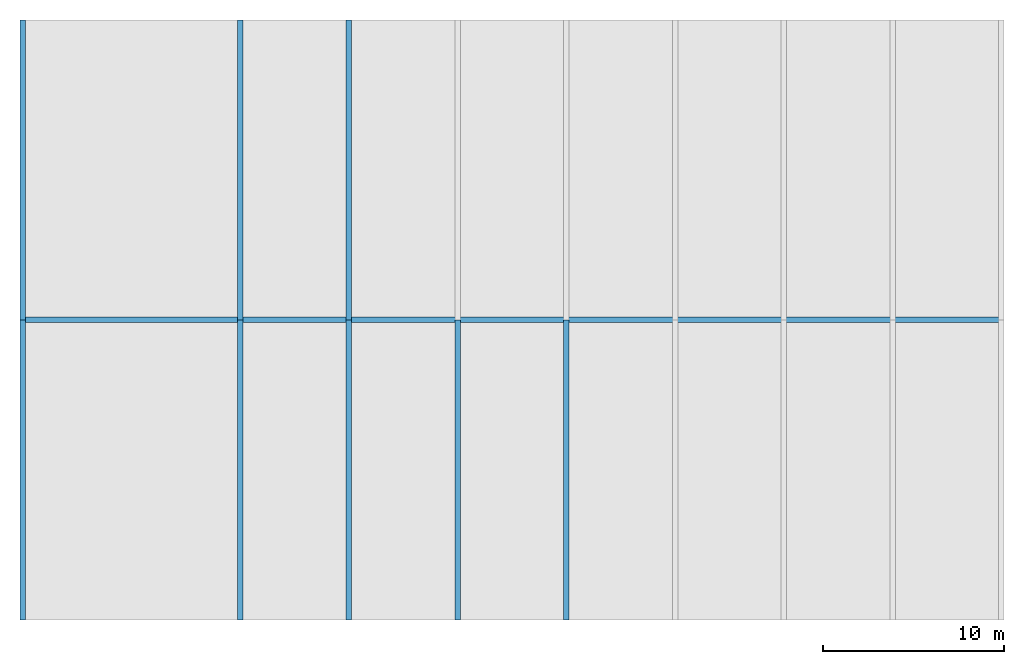
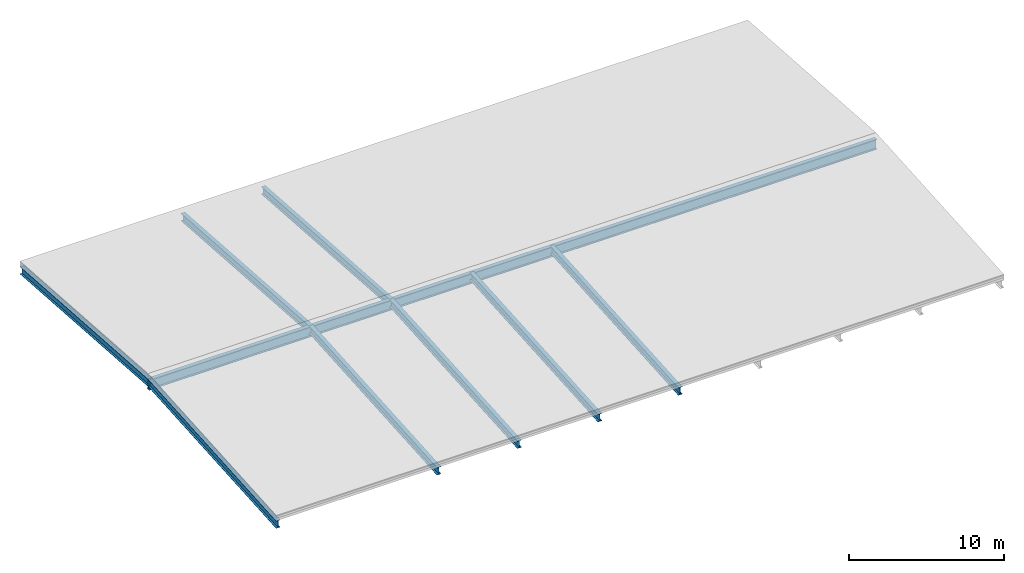
# One storey, part 1 of 3: 9 beams.
"""IFC2X3 building model written with IfcOpenShell, lengths in millimetres."""

from ifc_helpers import new_model, entity, si_unit, converted_unit, frame, origin, place, context, subcontext, project, spatial, faceted_brep, material, element, save


model = new_model("IFC2X3")

# Units and contexts
model_context = context("Model", 3, precision=1e-05, world=origin())
body_context = subcontext(model_context, "Body", "Model", "MODEL_VIEW")
ifc_project = project(units=[si_unit("LENGTHUNIT", "METRE", prefix="MILLI"), converted_unit("PLANEANGLEUNIT", "DEGREE", entity("IfcPlaneAngleMeasure", 0.0174532925199433), si_unit("PLANEANGLEUNIT", "RADIAN"), dimensions=[0, 0, 0, 0, 0, 0, 0]), si_unit("AREAUNIT", "SQUARE_METRE"), si_unit("VOLUMEUNIT", "CUBIC_METRE")], contexts=[model_context])

# Building, storey
building_placement = place(None, origin())
building = spatial("IfcBuilding", under=ifc_project, at=building_placement, CompositionType="ELEMENT")
storey_placement = place(building_placement, frame((0.0, 0.0, 7000.0), z_axis=(0.0, 0.0, 1.0), x_axis=(1.0, 0.0, 0.0)))
storey = spatial("IfcBuildingStorey", under=building, at=storey_placement, Name="Dach", CompositionType="ELEMENT", Elevation=7000.0)

# Beams
ifc_material_1 = material(Name="Stahl")
beam_1_placement = place(storey_placement, frame((-20.0, 16548.66666666668, 930.0), z_axis=(0.0, 0.0, 1.0), x_axis=(0.9999999996985275, 2.455494167264557e-05, 0.0)))
element("IfcBeam", 1, at=beam_1_placement, inside=storey, material=ifc_material_1, context=body_context, shape_type="Brep", body=[
    faceted_brep([(54300.00001637004, 0.0, 800.0), (54300.00001637004, 0.0, 767.0), (0.0, 0.0, 767.0), (0.0, 0.0, 800.0), (54300.00001637004, 0.0, 33.0), (54300.00001637004, 0.0, 0.0), (0.0, 0.0, 0.0), (0.0, 0.0, 33.0), (54300.00738285257, 299.9999999095599, 800.0), (54300.00738285258, 299.9999999095599, 767.0), (54300.00738285258, 158.7499999521424, 767.0), (54300.00738285258, 158.7499999521424, 33.0), (54300.00738285258, 299.9999999095599, 33.0), (54300.00738285257, 299.9999999095599, 0.0), (54300.00001637004, 0.0, 0.0), (54300.00001637004, 0.0, 33.0), (54300.00738285258, 141.2499999574175, 33.0), (54300.00738285258, 141.2499999574175, 767.0), (54300.00001637004, 0.0, 767.0), (54300.00001637004, 0.0, 800.0), (0.007399222424023577, 301.3333332424772, 33.0), (0.007399222424023577, 301.3333332424772, 0.0), (54300.00738285257, 299.9999999095599, 0.0), (54300.00738285258, 299.9999999095599, 33.0), (0.007399222424023577, 301.3333332424772, 800.0), (0.007399222424023577, 301.3333332424772, 767.0), (54300.00738285258, 299.9999999095599, 767.0), (54300.00738285257, 299.9999999095599, 800.0), (0.0, 0.0, 800.0), (0.0, 0.0, 767.0), (2.016520284087164e-11, 141.8777778205476, 767.0), (2.016520284087164e-11, 141.8777778205476, 33.0), (0.0, 0.0, 33.0), (0.0, 0.0, 0.0), (0.007399222424023577, 301.3333332424772, 0.0), (0.007399222424023577, 301.3333332424772, 33.0), (2.016520284087164e-11, 159.4555556036212, 33.0), (2.016520284087164e-11, 159.4555556036212, 767.0), (0.007399222424023577, 301.3333332424772, 767.0), (0.007399222424023577, 301.3333332424772, 800.0), (54300.00738285257, 299.9999999095599, 800.0), (54300.00001637004, 0.0, 800.0), (0.0, 0.0, 800.0), (0.007399222424023577, 301.3333332424772, 800.0), (54300.00001637004, 0.0, 767.0), (54300.00738285258, 141.2499999574175, 767.0), (2.016520284087164e-11, 141.8777778205476, 767.0), (0.0, 0.0, 767.0), (54300.00738285258, 141.2499999574175, 767.0), (54300.00738285258, 141.2499999574175, 33.0), (2.016520284087164e-11, 141.8777778205476, 33.0), (2.016520284087164e-11, 141.8777778205476, 767.0), (54300.00738285258, 141.2499999574175, 33.0), (54300.00001637004, 0.0, 33.0), (0.0, 0.0, 33.0), (2.016520284087164e-11, 141.8777778205476, 33.0), (54300.00001637004, 0.0, 0.0), (54300.00738285257, 299.9999999095599, 0.0), (0.007399222424023577, 301.3333332424772, 0.0), (0.0, 0.0, 0.0), (54300.00738285258, 299.9999999095599, 33.0), (54300.00738285258, 158.7499999521424, 33.0), (2.016520284087164e-11, 159.4555556036212, 33.0), (0.007399222424023577, 301.3333332424772, 33.0), (54300.00738285258, 158.7499999521424, 33.0), (54300.00738285258, 158.7499999521424, 767.0), (2.016520284087164e-11, 159.4555556036212, 767.0), (2.016520284087164e-11, 159.4555556036212, 33.0), (54300.00738285258, 158.7499999521424, 767.0), (54300.00738285258, 299.9999999095599, 767.0), (0.007399222424023577, 301.3333332424772, 767.0), (2.016520284087164e-11, 159.4555556036212, 767.0)], [[[0, 1, 2, 3]], [[4, 5, 6, 7]], [[8, 9, 10, 11, 12, 13, 14, 15, 16, 17, 18, 19]], [[20, 21, 22, 23]], [[24, 25, 26, 27]], [[28, 29, 30, 31, 32, 33, 34, 35, 36, 37, 38, 39]], [[40, 41, 42, 43]], [[44, 45, 46, 47]], [[48, 49, 50, 51]], [[52, 53, 54, 55]], [[56, 57, 58, 59]], [[60, 61, 62, 63]], [[64, 65, 66, 67]], [[68, 69, 70, 71]]], orient=[[False], [False], [False], [False], [False], [False], [False], [False], [False], [False], [False], [False], [False], [False]]),
])
ifc_material_2 = material(Name="Stahl")
beam_2_placement = place(storey_placement, frame((-20.0, 33250.0, -17.48170298587866), z_axis=(0.0, 0.0, 1.0), x_axis=(-5.296656030859425e-15, -1.0, 0.0)))
element("IfcBeam", 2, at=beam_2_placement, inside=storey, material=ifc_material_2, context=body_context, shape_type="Brep", body=[
    faceted_brep([(16550.00000000002, 0.0, 1757.288737665103), (16550.00000000002, -3.552713678800501e-15, 1727.288737665103), (0.0, 0.0, 570.0), (0.0, 0.0, 600.0), (16550.00000000002, 0.0, 1187.288737665102), (16550.00000000002, 0.0, 1157.288737665102), (0.0, -3.552713678800501e-15, 0.0), (0.0, 0.0, 30.00000000000091), (16550.00000000002, 300.0, 1757.288737665103), (16550.00000000002, 300.0, 1727.288737665103), (16550.00000000002, 157.75, 1727.288737665103), (16550.00000000002, 157.75, 1187.288737665102), (16550.00000000002, 300.0, 1187.288737665102), (16550.00000000002, 300.0, 1157.288737665102), (16550.00000000002, 0.0, 1157.288737665102), (16550.00000000002, 0.0, 1187.288737665102), (16550.00000000002, 142.25, 1187.288737665102), (16550.00000000002, 142.25, 1727.288737665103), (16550.00000000002, -3.552713678800501e-15, 1727.288737665103), (16550.00000000002, 0.0, 1757.288737665103), (0.0, 300.0, 30.0), (0.0, 300.0, 0.0), (16550.00000000002, 300.0, 1157.288737665102), (16550.00000000002, 300.0, 1187.288737665102), (0.0, 300.0, 600.0), (0.0, 300.0, 570.0), (16550.00000000002, 300.0, 1727.288737665103), (16550.00000000002, 300.0, 1757.288737665103), (0.0, 0.0, 600.0), (0.0, 0.0, 570.0), (0.0, 142.25, 570.0), (0.0, 142.25, 30.0), (0.0, 0.0, 30.00000000000091), (0.0, -3.552713678800501e-15, 0.0), (0.0, 300.0, 0.0), (0.0, 300.0, 30.0), (0.0, 157.75, 30.0), (0.0, 157.75, 570.0), (0.0, 300.0, 570.0), (0.0, 300.0, 600.0), (16550.00000000002, 300.0, 1757.288737665103), (16550.00000000002, 0.0, 1757.288737665103), (0.0, 0.0, 600.0), (0.0, 300.0, 600.0), (16550.00000000002, -3.552713678800501e-15, 1727.288737665103), (16550.00000000002, 142.25, 1727.288737665103), (0.0, 142.25, 570.0), (0.0, 0.0, 570.0), (16550.00000000002, 142.25, 1727.288737665103), (16550.00000000002, 142.25, 1187.288737665102), (0.0, 142.25, 30.0), (0.0, 142.25, 570.0), (16550.00000000002, 142.25, 1187.288737665102), (16550.00000000002, 0.0, 1187.288737665102), (0.0, 0.0, 30.00000000000091), (0.0, 142.25, 30.0), (16550.00000000002, 0.0, 1157.288737665102), (16550.00000000002, 300.0, 1157.288737665102), (0.0, 300.0, 0.0), (0.0, -3.552713678800501e-15, 0.0), (16550.00000000002, 300.0, 1187.288737665102), (16550.00000000002, 157.75, 1187.288737665102), (0.0, 157.75, 30.0), (0.0, 300.0, 30.0), (16550.00000000002, 157.75, 1187.288737665102), (16550.00000000002, 157.75, 1727.288737665103), (0.0, 157.75, 570.0), (0.0, 157.75, 30.0), (16550.00000000002, 157.75, 1727.288737665103), (16550.00000000002, 300.0, 1727.288737665103), (0.0, 300.0, 570.0), (0.0, 157.75, 570.0)], [[[0, 1, 2, 3]], [[4, 5, 6, 7]], [[8, 9, 10, 11, 12, 13, 14, 15, 16, 17, 18, 19]], [[20, 21, 22, 23]], [[24, 25, 26, 27]], [[28, 29, 30, 31, 32, 33, 34, 35, 36, 37, 38, 39]], [[40, 41, 42, 43]], [[44, 45, 46, 47]], [[48, 49, 50, 51]], [[52, 53, 54, 55]], [[56, 57, 58, 59]], [[60, 61, 62, 63]], [[64, 65, 66, 67]], [[68, 69, 70, 71]]], orient=[[False], [False], [False], [False], [False], [False], [False], [False], [False], [False], [False], [False], [False], [False]]),
])
ifc_material_3 = material(Name="Stahl")
beam_3_placement = place(storey_placement, frame((-20.00000000008766, 16699.99999999999, -17.48170298587684), z_axis=(0.0, 0.0, 1.0), x_axis=(5.296656030859434e-15, -1.0, 0.0)))
element("IfcBeam", 3, at=beam_3_placement, inside=storey, material=ifc_material_3, context=body_context, shape_type="Brep", body=[
    faceted_brep([(16549.99999999999, 0.0, 600.0), (16549.99999999999, 0.0, 570.0), (0.0, 0.0, 1727.288737665102), (0.0, 0.0, 1757.288737665102), (16549.99999999999, 0.0, 30.0), (16549.99999999999, 0.0, 0.0), (0.0, 0.0, 1157.2887376651), (0.0, 0.0, 1187.2887376651), (16549.99999999999, 300.0, 600.0), (16549.99999999999, 300.0, 570.0), (16549.99999999999, 157.75, 570.0), (16549.99999999999, 157.75, 30.0), (16549.99999999999, 300.0, 30.0), (16549.99999999999, 300.0, 0.0), (16549.99999999999, 0.0, 0.0), (16549.99999999999, 0.0, 30.0), (16549.99999999999, 142.25, 30.0), (16549.99999999999, 142.25, 570.0), (16549.99999999999, 0.0, 570.0), (16549.99999999999, 0.0, 600.0), (0.0, 300.0, 1187.2887376651), (0.0, 300.0, 1157.2887376651), (16549.99999999999, 300.0, 0.0), (16549.99999999999, 300.0, 30.0), (0.0, 300.0, 1757.288737665102), (0.0, 300.0, 1727.288737665102), (16549.99999999999, 300.0, 570.0), (16549.99999999999, 300.0, 600.0), (0.0, 0.0, 1757.288737665102), (0.0, 0.0, 1727.288737665102), (0.0, 142.25, 1727.288737665102), (0.0, 142.25, 1187.2887376651), (0.0, 0.0, 1187.2887376651), (0.0, 0.0, 1157.2887376651), (0.0, 300.0, 1157.2887376651), (0.0, 300.0, 1187.2887376651), (0.0, 157.75, 1187.2887376651), (0.0, 157.75, 1727.288737665102), (0.0, 300.0, 1727.288737665102), (0.0, 300.0, 1757.288737665102), (16549.99999999999, 300.0, 600.0), (16549.99999999999, 0.0, 600.0), (0.0, 0.0, 1757.288737665102), (0.0, 300.0, 1757.288737665102), (16549.99999999999, 0.0, 570.0), (16549.99999999999, 142.25, 570.0), (0.0, 142.25, 1727.288737665102), (0.0, 0.0, 1727.288737665102), (16549.99999999999, 142.25, 570.0), (16549.99999999999, 142.25, 30.0), (0.0, 142.25, 1187.2887376651), (0.0, 142.25, 1727.288737665102), (16549.99999999999, 142.25, 30.0), (16549.99999999999, 0.0, 30.0), (0.0, 0.0, 1187.2887376651), (0.0, 142.25, 1187.2887376651), (16549.99999999999, 0.0, 0.0), (16549.99999999999, 300.0, 0.0), (0.0, 300.0, 1157.2887376651), (0.0, 0.0, 1157.2887376651), (16549.99999999999, 300.0, 30.0), (16549.99999999999, 157.75, 30.0), (0.0, 157.75, 1187.2887376651), (0.0, 300.0, 1187.2887376651), (16549.99999999999, 157.75, 30.0), (16549.99999999999, 157.75, 570.0), (0.0, 157.75, 1727.288737665102), (0.0, 157.75, 1187.2887376651), (16549.99999999999, 157.75, 570.0), (16549.99999999999, 300.0, 570.0), (0.0, 300.0, 1727.288737665102), (0.0, 157.75, 1727.288737665102)], [[[0, 1, 2, 3]], [[4, 5, 6, 7]], [[8, 9, 10, 11, 12, 13, 14, 15, 16, 17, 18, 19]], [[20, 21, 22, 23]], [[24, 25, 26, 27]], [[28, 29, 30, 31, 32, 33, 34, 35, 36, 37, 38, 39]], [[40, 41, 42, 43]], [[44, 45, 46, 47]], [[48, 49, 50, 51]], [[52, 53, 54, 55]], [[56, 57, 58, 59]], [[60, 61, 62, 63]], [[64, 65, 66, 67]], [[68, 69, 70, 71]]], orient=[[False], [False], [False], [False], [False], [False], [False], [False], [False], [False], [False], [False], [False], [False]]),
])
ifc_material_4 = material(Name="Stahl")
beam_4_placement = place(storey_placement, frame((11980.0, 33250.0, -17.48170298587866), z_axis=(0.0, 0.0, 1.0), x_axis=(-5.27561881390943e-15, -1.0, 0.0)))
element("IfcBeam", 4, at=beam_4_placement, inside=storey, material=ifc_material_4, context=body_context, shape_type="Brep", body=[
    faceted_brep([(16550.00000000002, 0.0, 1757.288737665103), (16550.00000000002, 0.0, 1727.288737665102), (0.0, 0.0, 570.0), (0.0, 0.0, 600.0), (16550.00000000002, 0.0, 1187.288737665102), (16550.00000000002, 0.0, 1157.288737665102), (0.0, 1.818989403545857e-12, 0.0), (0.0, 0.0, 30.0), (16550.00000000001, 300.0, 1757.288737665103), (16550.00000000001, 300.0, 1727.288737665102), (16550.00000000001, 157.75, 1727.288737665102), (16550.00000000001, 157.75, 1187.288737665102), (16550.00000000001, 300.0, 1187.288737665102), (16550.00000000001, 300.0, 1157.288737665102), (16550.00000000002, 0.0, 1157.288737665102), (16550.00000000002, 0.0, 1187.288737665102), (16550.00000000001, 142.25, 1187.288737665102), (16550.00000000001, 142.25, 1727.288737665102), (16550.00000000002, 0.0, 1727.288737665102), (16550.00000000002, 0.0, 1757.288737665103), (0.0, 300.0, 30.0), (0.0, 300.0, 0.0), (16550.00000000001, 300.0, 1157.288737665102), (16550.00000000001, 300.0, 1187.288737665102), (0.0, 300.0, 600.0), (0.0, 300.0, 570.0), (16550.00000000001, 300.0, 1727.288737665102), (16550.00000000001, 300.0, 1757.288737665103), (0.0, 0.0, 600.0), (0.0, 0.0, 570.0), (0.0, 142.25, 570.0), (0.0, 142.2500000000018, 30.0), (0.0, 0.0, 30.0), (0.0, 1.818989403545857e-12, 0.0), (0.0, 300.0, 0.0), (0.0, 300.0, 30.0), (0.0, 157.75, 30.0), (0.0, 157.75, 570.0), (0.0, 300.0, 570.0), (0.0, 300.0, 600.0), (16550.00000000001, 300.0, 1757.288737665103), (16550.00000000002, 0.0, 1757.288737665103), (0.0, 0.0, 600.0), (0.0, 300.0, 600.0), (16550.00000000002, 0.0, 1727.288737665102), (16550.00000000001, 142.25, 1727.288737665102), (0.0, 142.25, 570.0), (0.0, 0.0, 570.0), (16550.00000000001, 142.25, 1727.288737665102), (16550.00000000001, 142.25, 1187.288737665102), (0.0, 142.2500000000018, 30.0), (0.0, 142.25, 570.0), (16550.00000000001, 142.25, 1187.288737665102), (16550.00000000002, 0.0, 1187.288737665102), (0.0, 0.0, 30.0), (0.0, 142.2500000000018, 30.0), (16550.00000000002, 0.0, 1157.288737665102), (16550.00000000001, 300.0, 1157.288737665102), (0.0, 300.0, 0.0), (0.0, 1.818989403545857e-12, 0.0), (16550.00000000001, 300.0, 1187.288737665102), (16550.00000000001, 157.75, 1187.288737665102), (0.0, 157.75, 30.0), (0.0, 300.0, 30.0), (16550.00000000001, 157.75, 1187.288737665102), (16550.00000000001, 157.75, 1727.288737665102), (0.0, 157.75, 570.0), (0.0, 157.75, 30.0), (16550.00000000001, 157.75, 1727.288737665102), (16550.00000000001, 300.0, 1727.288737665102), (0.0, 300.0, 570.0), (0.0, 157.75, 570.0)], [[[0, 1, 2, 3]], [[4, 5, 6, 7]], [[8, 9, 10, 11, 12, 13, 14, 15, 16, 17, 18, 19]], [[20, 21, 22, 23]], [[24, 25, 26, 27]], [[28, 29, 30, 31, 32, 33, 34, 35, 36, 37, 38, 39]], [[40, 41, 42, 43]], [[44, 45, 46, 47]], [[48, 49, 50, 51]], [[52, 53, 54, 55]], [[56, 57, 58, 59]], [[60, 61, 62, 63]], [[64, 65, 66, 67]], [[68, 69, 70, 71]]], orient=[[False], [False], [False], [False], [False], [False], [False], [False], [False], [False], [False], [False], [False], [False]]),
])
ifc_material_5 = material(Name="Stahl")
beam_5_placement = place(storey_placement, frame((11979.99999999991, 16699.99999999999, -17.48170298587684), z_axis=(0.0, 0.0, 1.0), x_axis=(5.275618813909437e-15, -1.0, 0.0)))
element("IfcBeam", 5, at=beam_5_placement, inside=storey, material=ifc_material_5, context=body_context, shape_type="Brep", body=[
    faceted_brep([(16549.99999999999, 0.0, 600.0000000000009), (16549.99999999999, 0.0, 570.0000000000009), (0.0, 0.0, 1727.288737665102), (0.0, 0.0, 1757.288737665102), (16549.99999999999, 0.0, 30.0), (16549.99999999999, 0.0, 0.0), (0.0, 0.0, 1157.2887376651), (0.0, 0.0, 1187.2887376651), (16549.99999999999, 300.0, 600.0000000000009), (16549.99999999999, 300.0, 570.0000000000009), (16549.99999999999, 157.75, 570.0000000000009), (16549.99999999999, 157.75, 30.0), (16549.99999999999, 300.0, 30.0), (16549.99999999999, 300.0, 0.0), (16549.99999999999, 0.0, 0.0), (16549.99999999999, 0.0, 30.0), (16549.99999999999, 142.25, 30.0), (16549.99999999999, 142.25, 570.0000000000009), (16549.99999999999, 0.0, 570.0000000000009), (16549.99999999999, 0.0, 600.0000000000009), (3.637978807091713e-12, 300.0, 1187.2887376651), (3.637978807091713e-12, 300.0, 1157.2887376651), (16549.99999999999, 300.0, 0.0), (16549.99999999999, 300.0, 30.0), (3.637978807091713e-12, 300.0, 1757.288737665102), (3.637978807091713e-12, 300.0, 1727.288737665102), (16549.99999999999, 300.0, 570.0000000000009), (16549.99999999999, 300.0, 600.0000000000009), (0.0, 0.0, 1757.288737665102), (0.0, 0.0, 1727.288737665102), (3.637978807091713e-12, 142.25, 1727.288737665102), (3.637978807091713e-12, 142.25, 1187.2887376651), (0.0, 0.0, 1187.2887376651), (0.0, 0.0, 1157.2887376651), (3.637978807091713e-12, 300.0, 1157.2887376651), (3.637978807091713e-12, 300.0, 1187.2887376651), (3.637978807091713e-12, 157.75, 1187.2887376651), (3.637978807091713e-12, 157.75, 1727.288737665102), (3.637978807091713e-12, 300.0, 1727.288737665102), (3.637978807091713e-12, 300.0, 1757.288737665102), (16549.99999999999, 300.0, 600.0000000000009), (16549.99999999999, 0.0, 600.0000000000009), (0.0, 0.0, 1757.288737665102), (3.637978807091713e-12, 300.0, 1757.288737665102), (16549.99999999999, 0.0, 570.0000000000009), (16549.99999999999, 142.25, 570.0000000000009), (3.637978807091713e-12, 142.25, 1727.288737665102), (0.0, 0.0, 1727.288737665102), (16549.99999999999, 142.25, 570.0000000000009), (16549.99999999999, 142.25, 30.0), (3.637978807091713e-12, 142.25, 1187.2887376651), (3.637978807091713e-12, 142.25, 1727.288737665102), (16549.99999999999, 142.25, 30.0), (16549.99999999999, 0.0, 30.0), (0.0, 0.0, 1187.2887376651), (3.637978807091713e-12, 142.25, 1187.2887376651), (16549.99999999999, 0.0, 0.0), (16549.99999999999, 300.0, 0.0), (3.637978807091713e-12, 300.0, 1157.2887376651), (0.0, 0.0, 1157.2887376651), (16549.99999999999, 300.0, 30.0), (16549.99999999999, 157.75, 30.0), (3.637978807091713e-12, 157.75, 1187.2887376651), (3.637978807091713e-12, 300.0, 1187.2887376651), (16549.99999999999, 157.75, 30.0), (16549.99999999999, 157.75, 570.0000000000009), (3.637978807091713e-12, 157.75, 1727.288737665102), (3.637978807091713e-12, 157.75, 1187.2887376651), (16549.99999999999, 157.75, 570.0000000000009), (16549.99999999999, 300.0, 570.0000000000009), (3.637978807091713e-12, 300.0, 1727.288737665102), (3.637978807091713e-12, 157.75, 1727.288737665102)], [[[0, 1, 2, 3]], [[4, 5, 6, 7]], [[8, 9, 10, 11, 12, 13, 14, 15, 16, 17, 18, 19]], [[20, 21, 22, 23]], [[24, 25, 26, 27]], [[28, 29, 30, 31, 32, 33, 34, 35, 36, 37, 38, 39]], [[40, 41, 42, 43]], [[44, 45, 46, 47]], [[48, 49, 50, 51]], [[52, 53, 54, 55]], [[56, 57, 58, 59]], [[60, 61, 62, 63]], [[64, 65, 66, 67]], [[68, 69, 70, 71]]], orient=[[False], [False], [False], [False], [False], [False], [False], [False], [False], [False], [False], [False], [False], [False]]),
])
ifc_material_6 = material(Name="Stahl")
beam_6_placement = place(storey_placement, frame((29979.99999999991, 16699.99999999999, -17.48170298587684), z_axis=(0.0, 0.0, 1.0), x_axis=(5.275618813909437e-15, -1.0, 0.0)))
element("IfcBeam", 6, at=beam_6_placement, inside=storey, material=ifc_material_6, context=body_context, shape_type="Brep", body=[
    faceted_brep([(16549.99999999999, 0.0, 600.0000000000009), (16549.99999999999, 0.0, 570.0000000000009), (0.0, 0.0, 1727.288737665102), (0.0, 0.0, 1757.288737665102), (16549.99999999999, 0.0, 30.0), (16549.99999999999, 0.0, 0.0), (0.0, 0.0, 1157.2887376651), (0.0, 0.0, 1187.2887376651), (16549.99999999999, 300.0, 600.0000000000009), (16549.99999999999, 300.0, 570.0000000000009), (16549.99999999999, 157.75, 570.0000000000009), (16549.99999999999, 157.75, 30.0), (16549.99999999999, 300.0, 30.0), (16549.99999999999, 300.0, 0.0), (16549.99999999999, 0.0, 0.0), (16549.99999999999, 0.0, 30.0), (16549.99999999999, 142.25, 30.0), (16549.99999999999, 142.25, 570.0000000000009), (16549.99999999999, 0.0, 570.0000000000009), (16549.99999999999, 0.0, 600.0000000000009), (3.637978807091713e-12, 300.0, 1187.2887376651), (3.637978807091713e-12, 300.0, 1157.2887376651), (16549.99999999999, 300.0, 0.0), (16549.99999999999, 300.0, 30.0), (3.637978807091713e-12, 300.0, 1757.288737665102), (3.637978807091713e-12, 300.0, 1727.288737665102), (16549.99999999999, 300.0, 570.0000000000009), (16549.99999999999, 300.0, 600.0000000000009), (0.0, 0.0, 1757.288737665102), (0.0, 0.0, 1727.288737665102), (3.637978807091713e-12, 142.25, 1727.288737665102), (3.637978807091713e-12, 142.25, 1187.2887376651), (0.0, 0.0, 1187.2887376651), (0.0, 0.0, 1157.2887376651), (3.637978807091713e-12, 300.0, 1157.2887376651), (3.637978807091713e-12, 300.0, 1187.2887376651), (3.637978807091713e-12, 157.75, 1187.2887376651), (3.637978807091713e-12, 157.75, 1727.288737665102), (3.637978807091713e-12, 300.0, 1727.288737665102), (3.637978807091713e-12, 300.0, 1757.288737665102), (16549.99999999999, 300.0, 600.0000000000009), (16549.99999999999, 0.0, 600.0000000000009), (0.0, 0.0, 1757.288737665102), (3.637978807091713e-12, 300.0, 1757.288737665102), (16549.99999999999, 0.0, 570.0000000000009), (16549.99999999999, 142.25, 570.0000000000009), (3.637978807091713e-12, 142.25, 1727.288737665102), (0.0, 0.0, 1727.288737665102), (16549.99999999999, 142.25, 570.0000000000009), (16549.99999999999, 142.25, 30.0), (3.637978807091713e-12, 142.25, 1187.2887376651), (3.637978807091713e-12, 142.25, 1727.288737665102), (16549.99999999999, 142.25, 30.0), (16549.99999999999, 0.0, 30.0), (0.0, 0.0, 1187.2887376651), (3.637978807091713e-12, 142.25, 1187.2887376651), (16549.99999999999, 0.0, 0.0), (16549.99999999999, 300.0, 0.0), (3.637978807091713e-12, 300.0, 1157.2887376651), (0.0, 0.0, 1157.2887376651), (16549.99999999999, 300.0, 30.0), (16549.99999999999, 157.75, 30.0), (3.637978807091713e-12, 157.75, 1187.2887376651), (3.637978807091713e-12, 300.0, 1187.2887376651), (16549.99999999999, 157.75, 30.0), (16549.99999999999, 157.75, 570.0000000000009), (3.637978807091713e-12, 157.75, 1727.288737665102), (3.637978807091713e-12, 157.75, 1187.2887376651), (16549.99999999999, 157.75, 570.0000000000009), (16549.99999999999, 300.0, 570.0000000000009), (3.637978807091713e-12, 300.0, 1727.288737665102), (3.637978807091713e-12, 157.75, 1727.288737665102)], [[[0, 1, 2, 3]], [[4, 5, 6, 7]], [[8, 9, 10, 11, 12, 13, 14, 15, 16, 17, 18, 19]], [[20, 21, 22, 23]], [[24, 25, 26, 27]], [[28, 29, 30, 31, 32, 33, 34, 35, 36, 37, 38, 39]], [[40, 41, 42, 43]], [[44, 45, 46, 47]], [[48, 49, 50, 51]], [[52, 53, 54, 55]], [[56, 57, 58, 59]], [[60, 61, 62, 63]], [[64, 65, 66, 67]], [[68, 69, 70, 71]]], orient=[[False], [False], [False], [False], [False], [False], [False], [False], [False], [False], [False], [False], [False], [False]]),
])
ifc_material_7 = material(Name="Stahl")
beam_7_placement = place(storey_placement, frame((23979.99999999991, 16699.99999999999, -17.48170298587684), z_axis=(0.0, 0.0, 1.0), x_axis=(5.275618813909437e-15, -1.0, 0.0)))
element("IfcBeam", 7, at=beam_7_placement, inside=storey, material=ifc_material_7, context=body_context, shape_type="Brep", body=[
    faceted_brep([(16549.99999999999, 0.0, 600.0000000000009), (16549.99999999999, 0.0, 570.0000000000009), (0.0, 0.0, 1727.288737665102), (0.0, 0.0, 1757.288737665102), (16549.99999999999, 0.0, 30.0), (16549.99999999999, 0.0, 0.0), (0.0, 0.0, 1157.2887376651), (0.0, 0.0, 1187.2887376651), (16549.99999999999, 300.0, 600.0000000000009), (16549.99999999999, 300.0, 570.0000000000009), (16549.99999999999, 157.75, 570.0000000000009), (16549.99999999999, 157.75, 30.0), (16549.99999999999, 300.0, 30.0), (16549.99999999999, 300.0, 0.0), (16549.99999999999, 0.0, 0.0), (16549.99999999999, 0.0, 30.0), (16549.99999999999, 142.25, 30.0), (16549.99999999999, 142.25, 570.0000000000009), (16549.99999999999, 0.0, 570.0000000000009), (16549.99999999999, 0.0, 600.0000000000009), (0.0, 300.0, 1187.2887376651), (0.0, 300.0, 1157.2887376651), (16549.99999999999, 300.0, 0.0), (16549.99999999999, 300.0, 30.0), (0.0, 300.0, 1757.288737665102), (0.0, 300.0, 1727.288737665102), (16549.99999999999, 300.0, 570.0000000000009), (16549.99999999999, 300.0, 600.0000000000009), (0.0, 0.0, 1757.288737665102), (0.0, 0.0, 1727.288737665102), (0.0, 142.25, 1727.288737665102), (0.0, 142.25, 1187.2887376651), (0.0, 0.0, 1187.2887376651), (0.0, 0.0, 1157.2887376651), (0.0, 300.0, 1157.2887376651), (0.0, 300.0, 1187.2887376651), (0.0, 157.75, 1187.2887376651), (0.0, 157.75, 1727.288737665102), (0.0, 300.0, 1727.288737665102), (0.0, 300.0, 1757.288737665102), (16549.99999999999, 300.0, 600.0000000000009), (16549.99999999999, 0.0, 600.0000000000009), (0.0, 0.0, 1757.288737665102), (0.0, 300.0, 1757.288737665102), (16549.99999999999, 0.0, 570.0000000000009), (16549.99999999999, 142.25, 570.0000000000009), (0.0, 142.25, 1727.288737665102), (0.0, 0.0, 1727.288737665102), (16549.99999999999, 142.25, 570.0000000000009), (16549.99999999999, 142.25, 30.0), (0.0, 142.25, 1187.2887376651), (0.0, 142.25, 1727.288737665102), (16549.99999999999, 142.25, 30.0), (16549.99999999999, 0.0, 30.0), (0.0, 0.0, 1187.2887376651), (0.0, 142.25, 1187.2887376651), (16549.99999999999, 0.0, 0.0), (16549.99999999999, 300.0, 0.0), (0.0, 300.0, 1157.2887376651), (0.0, 0.0, 1157.2887376651), (16549.99999999999, 300.0, 30.0), (16549.99999999999, 157.75, 30.0), (0.0, 157.75, 1187.2887376651), (0.0, 300.0, 1187.2887376651), (16549.99999999999, 157.75, 30.0), (16549.99999999999, 157.75, 570.0000000000009), (0.0, 157.75, 1727.288737665102), (0.0, 157.75, 1187.2887376651), (16549.99999999999, 157.75, 570.0000000000009), (16549.99999999999, 300.0, 570.0000000000009), (0.0, 300.0, 1727.288737665102), (0.0, 157.75, 1727.288737665102)], [[[0, 1, 2, 3]], [[4, 5, 6, 7]], [[8, 9, 10, 11, 12, 13, 14, 15, 16, 17, 18, 19]], [[20, 21, 22, 23]], [[24, 25, 26, 27]], [[28, 29, 30, 31, 32, 33, 34, 35, 36, 37, 38, 39]], [[40, 41, 42, 43]], [[44, 45, 46, 47]], [[48, 49, 50, 51]], [[52, 53, 54, 55]], [[56, 57, 58, 59]], [[60, 61, 62, 63]], [[64, 65, 66, 67]], [[68, 69, 70, 71]]], orient=[[False], [False], [False], [False], [False], [False], [False], [False], [False], [False], [False], [False], [False], [False]]),
])
ifc_material_8 = material(Name="Stahl")
beam_8_placement = place(storey_placement, frame((17979.99999999991, 16699.99999999999, -17.48170298587684), z_axis=(0.0, 0.0, 1.0), x_axis=(5.275618813909437e-15, -1.0, 0.0)))
element("IfcBeam", 8, at=beam_8_placement, inside=storey, material=ifc_material_8, context=body_context, shape_type="Brep", body=[
    faceted_brep([(16549.99999999999, 0.0, 600.0000000000009), (16549.99999999999, 0.0, 570.0000000000009), (0.0, 0.0, 1727.288737665102), (0.0, 0.0, 1757.288737665102), (16549.99999999999, 0.0, 30.0), (16549.99999999999, 0.0, 0.0), (0.0, 0.0, 1157.2887376651), (0.0, 0.0, 1187.2887376651), (16549.99999999999, 300.0, 600.0000000000009), (16549.99999999999, 300.0, 570.0000000000009), (16549.99999999999, 157.75, 570.0000000000009), (16549.99999999999, 157.75, 30.0), (16549.99999999999, 300.0, 30.0), (16549.99999999999, 300.0, 0.0), (16549.99999999999, 0.0, 0.0), (16549.99999999999, 0.0, 30.0), (16549.99999999999, 142.25, 30.0), (16549.99999999999, 142.25, 570.0000000000009), (16549.99999999999, 0.0, 570.0000000000009), (16549.99999999999, 0.0, 600.0000000000009), (3.637978807091713e-12, 300.0, 1187.2887376651), (3.637978807091713e-12, 300.0, 1157.2887376651), (16549.99999999999, 300.0, 0.0), (16549.99999999999, 300.0, 30.0), (3.637978807091713e-12, 300.0, 1757.288737665102), (3.637978807091713e-12, 300.0, 1727.288737665102), (16549.99999999999, 300.0, 570.0000000000009), (16549.99999999999, 300.0, 600.0000000000009), (0.0, 0.0, 1757.288737665102), (0.0, 0.0, 1727.288737665102), (0.0, 142.25, 1727.288737665102), (0.0, 142.25, 1187.2887376651), (0.0, 0.0, 1187.2887376651), (0.0, 0.0, 1157.2887376651), (3.637978807091713e-12, 300.0, 1157.2887376651), (3.637978807091713e-12, 300.0, 1187.2887376651), (0.0, 157.75, 1187.2887376651), (0.0, 157.75, 1727.288737665102), (3.637978807091713e-12, 300.0, 1727.288737665102), (3.637978807091713e-12, 300.0, 1757.288737665102), (16549.99999999999, 300.0, 600.0000000000009), (16549.99999999999, 0.0, 600.0000000000009), (0.0, 0.0, 1757.288737665102), (3.637978807091713e-12, 300.0, 1757.288737665102), (16549.99999999999, 0.0, 570.0000000000009), (16549.99999999999, 142.25, 570.0000000000009), (0.0, 142.25, 1727.288737665102), (0.0, 0.0, 1727.288737665102), (16549.99999999999, 142.25, 570.0000000000009), (16549.99999999999, 142.25, 30.0), (0.0, 142.25, 1187.2887376651), (0.0, 142.25, 1727.288737665102), (16549.99999999999, 142.25, 30.0), (16549.99999999999, 0.0, 30.0), (0.0, 0.0, 1187.2887376651), (0.0, 142.25, 1187.2887376651), (16549.99999999999, 0.0, 0.0), (16549.99999999999, 300.0, 0.0), (3.637978807091713e-12, 300.0, 1157.2887376651), (0.0, 0.0, 1157.2887376651), (16549.99999999999, 300.0, 30.0), (16549.99999999999, 157.75, 30.0), (0.0, 157.75, 1187.2887376651), (3.637978807091713e-12, 300.0, 1187.2887376651), (16549.99999999999, 157.75, 30.0), (16549.99999999999, 157.75, 570.0000000000009), (0.0, 157.75, 1727.288737665102), (0.0, 157.75, 1187.2887376651), (16549.99999999999, 157.75, 570.0000000000009), (16549.99999999999, 300.0, 570.0000000000009), (3.637978807091713e-12, 300.0, 1727.288737665102), (0.0, 157.75, 1727.288737665102)], [[[0, 1, 2, 3]], [[4, 5, 6, 7]], [[8, 9, 10, 11, 12, 13, 14, 15, 16, 17, 18, 19]], [[20, 21, 22, 23]], [[24, 25, 26, 27]], [[28, 29, 30, 31, 32, 33, 34, 35, 36, 37, 38, 39]], [[40, 41, 42, 43]], [[44, 45, 46, 47]], [[48, 49, 50, 51]], [[52, 53, 54, 55]], [[56, 57, 58, 59]], [[60, 61, 62, 63]], [[64, 65, 66, 67]], [[68, 69, 70, 71]]], orient=[[False], [False], [False], [False], [False], [False], [False], [False], [False], [False], [False], [False], [False], [False]]),
])
ifc_material_9 = material(Name="Stahl")
beam_9_placement = place(storey_placement, frame((17980.0, 33250.0, -17.48170298587866), z_axis=(0.0, 0.0, 1.0), x_axis=(-5.27561881390943e-15, -1.0, 0.0)))
element("IfcBeam", 9, at=beam_9_placement, inside=storey, material=ifc_material_9, context=body_context, shape_type="Brep", body=[
    faceted_brep([(16550.00000000001, 0.0, 1757.288737665103), (16550.00000000001, 0.0, 1727.288737665102), (0.0, 0.0, 570.0), (0.0, 0.0, 600.0), (16550.00000000001, 0.0, 1187.288737665102), (16550.00000000001, 0.0, 1157.288737665102), (0.0, 0.0, 0.0), (0.0, 0.0, 30.0), (16550.00000000001, 300.0, 1757.288737665103), (16550.00000000001, 300.0, 1727.288737665102), (16550.00000000001, 157.75, 1727.288737665102), (16550.00000000001, 157.75, 1187.288737665102), (16550.00000000001, 300.0, 1187.288737665102), (16550.00000000001, 300.0, 1157.288737665102), (16550.00000000001, 0.0, 1157.288737665102), (16550.00000000001, 0.0, 1187.288737665102), (16550.00000000001, 142.25, 1187.288737665102), (16550.00000000001, 142.25, 1727.288737665102), (16550.00000000001, 0.0, 1727.288737665102), (16550.00000000001, 0.0, 1757.288737665103), (0.0, 300.0, 30.0), (0.0, 300.0, 0.0), (16550.00000000001, 300.0, 1157.288737665102), (16550.00000000001, 300.0, 1187.288737665102), (0.0, 300.0, 600.0), (0.0, 300.0, 570.0), (16550.00000000001, 300.0, 1727.288737665102), (16550.00000000001, 300.0, 1757.288737665103), (0.0, 0.0, 600.0), (0.0, 0.0, 570.0), (0.0, 142.2500000000036, 570.0), (0.0, 142.2500000000036, 30.0), (0.0, 0.0, 30.0), (0.0, 0.0, 0.0), (0.0, 300.0, 0.0), (0.0, 300.0, 30.0), (0.0, 157.75, 30.0), (0.0, 157.75, 570.0), (0.0, 300.0, 570.0), (0.0, 300.0, 600.0), (16550.00000000001, 300.0, 1757.288737665103), (16550.00000000001, 0.0, 1757.288737665103), (0.0, 0.0, 600.0), (0.0, 300.0, 600.0), (16550.00000000001, 0.0, 1727.288737665102), (16550.00000000001, 142.25, 1727.288737665102), (0.0, 142.2500000000036, 570.0), (0.0, 0.0, 570.0), (16550.00000000001, 142.25, 1727.288737665102), (16550.00000000001, 142.25, 1187.288737665102), (0.0, 142.2500000000036, 30.0), (0.0, 142.2500000000036, 570.0), (16550.00000000001, 142.25, 1187.288737665102), (16550.00000000001, 0.0, 1187.288737665102), (0.0, 0.0, 30.0), (0.0, 142.2500000000036, 30.0), (16550.00000000001, 0.0, 1157.288737665102), (16550.00000000001, 300.0, 1157.288737665102), (0.0, 300.0, 0.0), (0.0, 0.0, 0.0), (16550.00000000001, 300.0, 1187.288737665102), (16550.00000000001, 157.75, 1187.288737665102), (0.0, 157.75, 30.0), (0.0, 300.0, 30.0), (16550.00000000001, 157.75, 1187.288737665102), (16550.00000000001, 157.75, 1727.288737665102), (0.0, 157.75, 570.0), (0.0, 157.75, 30.0), (16550.00000000001, 157.75, 1727.288737665102), (16550.00000000001, 300.0, 1727.288737665102), (0.0, 300.0, 570.0), (0.0, 157.75, 570.0)], [[[0, 1, 2, 3]], [[4, 5, 6, 7]], [[8, 9, 10, 11, 12, 13, 14, 15, 16, 17, 18, 19]], [[20, 21, 22, 23]], [[24, 25, 26, 27]], [[28, 29, 30, 31, 32, 33, 34, 35, 36, 37, 38, 39]], [[40, 41, 42, 43]], [[44, 45, 46, 47]], [[48, 49, 50, 51]], [[52, 53, 54, 55]], [[56, 57, 58, 59]], [[60, 61, 62, 63]], [[64, 65, 66, 67]], [[68, 69, 70, 71]]], orient=[[False], [False], [False], [False], [False], [False], [False], [False], [False], [False], [False], [False], [False], [False]]),
])

save(model, "model.ifc")
